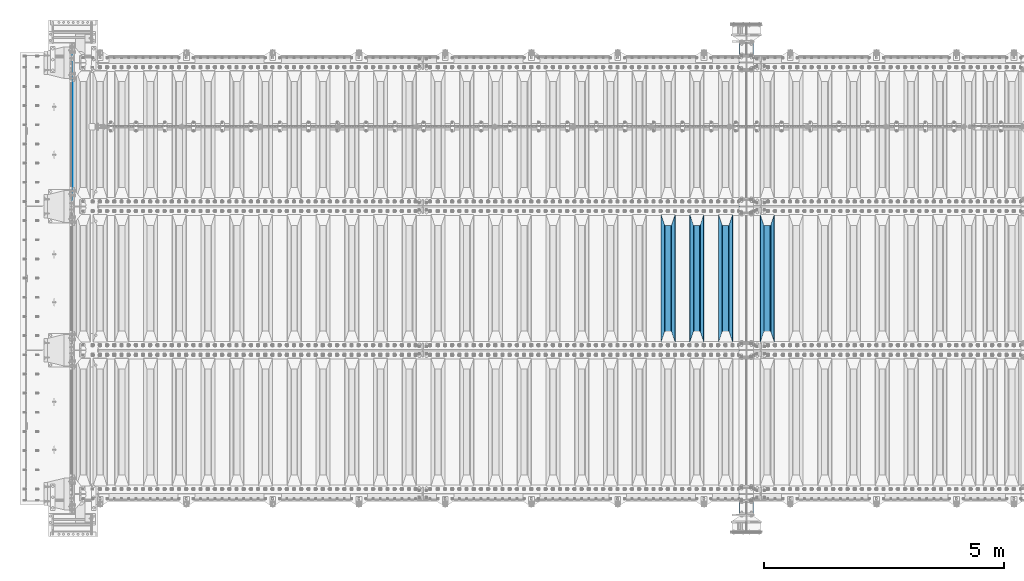
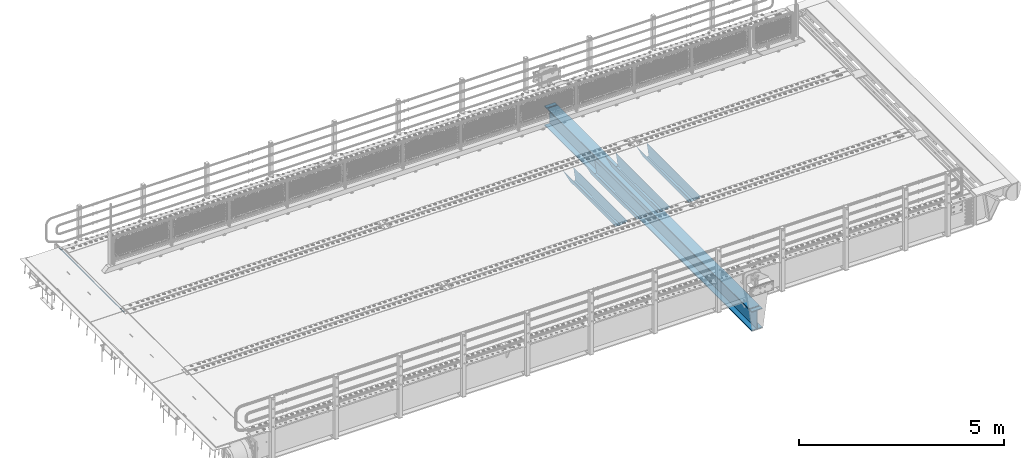
# One storey, part 126 of 270: 6 beams.
"""IFC2X3 building model written with IfcOpenShell, lengths in millimetres."""

from ifc_helpers import new_model, si_unit, frame, origin_with_axes, place, context, subcontext, project, spatial, faceted_brep, material, type_object, element, save


model = new_model("IFC2X3")

# Units and contexts
model_context = context("Model", 3, precision=1e-05, world=origin_with_axes())
body_context = subcontext(model_context, "Body", "Model", "MODEL_VIEW")
ifc_project = project(units=[si_unit("LENGTHUNIT", "METRE", prefix="MILLI"), si_unit("AREAUNIT", "SQUARE_METRE"), si_unit("VOLUMEUNIT", "CUBIC_METRE"), si_unit("MASSUNIT", "GRAM", prefix="KILO"), si_unit("TIMEUNIT", "SECOND"), si_unit("PLANEANGLEUNIT", "RADIAN"), si_unit("SOLIDANGLEUNIT", "STERADIAN"), si_unit("THERMODYNAMICTEMPERATUREUNIT", "DEGREE_CELSIUS"), si_unit("LUMINOUSINTENSITYUNIT", "LUMEN")], contexts=[model_context])

# Site, building, storey
site_placement = place(None, origin_with_axes())
site = spatial("IfcSite", under=ifc_project, at=site_placement, CompositionType="ELEMENT")
building_placement = place(site_placement, origin_with_axes())
building = spatial("IfcBuilding", under=site, at=building_placement, Name="Standard", CompositionType="ELEMENT")
storey_placement = place(building_placement, origin_with_axes())
storey = spatial("IfcBuildingStorey", under=building, at=storey_placement, Name="Undefined", CompositionType="ELEMENT", Elevation=0.0)

# Beams
ifc_material = material(Name="STEEL/S355N")
beam_type_1 = type_object("IfcBeamType", Name="D20", PredefinedType="NOTDEFINED")
beam_1_placement = place(storey_placement, frame((-35.0, -17995.0, -25.9999999971316), z_axis=(0.0, 0.0, 1.0), x_axis=(0.0, 1.0, 0.0)))
element("IfcBeam", 1, at=beam_1_placement, inside=storey, type_object=beam_type_1, material=ifc_material, ObjectType="D20", context=body_context, shape_type="Brep", body=[
    faceted_brep([(0.0, -10.0, 0.0), (0.0, -7.07106781186667, -7.07106781186547), (3144.99999999998, -7.07106781186548, -7.07106781186548), (3144.99999999998, -10.0, 0.0), (0.0, 0.0, -10.0), (3144.99999999998, 0.0, -10.0), (0.0, 7.07106781186667, -7.07106781186547), (3144.99999999998, 7.07106781186548, -7.07106781186547), (0.0, 10.0, 0.0), (3144.99999999998, 10.0, 0.0), (0.0, 7.07106781186667, 7.07106781186548), (3144.99999999998, 7.07106781186548, 7.07106781186548), (0.0, 0.0, 10.0), (3144.99999999998, 0.0, 10.0), (0.0, -7.07106781186667, 7.07106781186548), (3144.99999999998, -7.07106781186548, 7.07106781186548)], [[[0, 1, 2, 3]], [[1, 4, 5, 2]], [[4, 6, 7, 5]], [[6, 8, 9, 7]], [[8, 10, 11, 9]], [[10, 12, 13, 11]], [[12, 14, 15, 13]], [[14, 0, 3, 15]], [[5, 7, 9, 11, 13, 15, 3, 2]], [[14, 12, 10, 8, 6, 4, 1, 0]]]),
])
beam_type_2 = type_object("IfcBeamType", PredefinedType="NOTDEFINED")
beam_2_placement = place(storey_placement, frame((14470.0, -20825.0, -115.0), z_axis=(0.0, 0.0, 1.0), x_axis=(0.0, 1.0, 0.0)))
element("IfcBeam", 2, at=beam_2_placement, inside=storey, type_object=beam_type_2, material=ifc_material, context=body_context, shape_type="Brep", body=[
    faceted_brep([(0.0, 150.0, 115.0), (0.0, 143.689999999999, 115.0), (2650.00000000297, 143.689999999999, 115.0), (2650.00000000297, 150.0, 115.0), (2650.00000000297, 142.059565218398, 110.000000003096), (2650.00000000297, 148.3695652184, 110.000000003096), (2441.90079219209, -80.1103600731112, -98.0992078077845), (2437.7588105432, -77.5672621345584, -102.241189456673), (2434.06523489747, -74.4080125315522, -105.934765102404), (2430.9108609509, -70.710272125576, -109.089139048974), (2428.37322971128, -66.5649389910068, -111.626770288588), (2426.51472138055, -62.0739139532889, -113.485278619323), (2425.38102192092, -57.3475956567672, -114.618978078955), (2424.99999999987, -52.5021667386536, -115.0), (2424.99999999987, 52.5021667386536, -115.0), (2425.38102192092, 57.3475956567672, -114.618978078955), (2426.51472138055, 62.0739139532889, -113.485278619323), (2428.37322971128, 66.5649389910068, -111.626770288588), (2430.9108609509, 70.710272125576, -109.089139048974), (2434.06523489747, 74.4080125315522, -105.934765102404), (2437.7588105432, 77.5672621345584, -102.241189456673), (2441.90079219209, 80.1103600731112, -98.0992078077846), (2446.38936140511, 81.9747917625791, -93.6106385947584), (2448.2494850041, 76.2713538057251, -91.7505149957729), (2444.62967112263, 74.76777986261, -95.3703288772456), (2441.28936334126, 72.7168944282894, -98.710636658607), (2438.31067330439, 70.1691124903846, -101.689326695487), (2435.76682334747, 67.1870637758839, -104.233176652398), (2433.72034654133, 63.8440531834895, -106.279653458539), (2432.22154950042, 60.222258798236, -107.778450499454), (2431.30727574265, 56.4107117849089, -108.692724257221), (2430.99999999987, 52.5031078186876, -109.0), (2430.99999999987, -52.5031078186876, -109.0), (2431.30727574265, -56.4107117849089, -108.692724257221), (2432.22154950042, -60.222258798236, -107.778450499454), (2433.72034654133, -63.8440531834895, -106.279653458539), (2435.76682334747, -67.1870637758839, -104.233176652398), (2438.31067330438, -70.1691124903846, -101.689326695487), (2441.28936334126, -72.7168944282894, -98.7106366586071), (2444.62967112263, -74.76777986261, -95.3703288772457), (2448.2494850041, -76.2713538057251, -91.7505149957729), (2650.00000000297, -142.059565218398, 110.000000003096), (2650.00000000297, -148.3695652184, 110.000000003096), (2446.38936140511, -81.9747917625791, -93.6106385947584), (2650.00000000297, -143.689999999999, 115.0), (2650.00000000297, -150.0, 115.0), (0.0, -143.689999999999, 115.0), (0.0, -150.0, 115.0), (0.0, -148.369565218261, 110.000000002672), (203.610638597431, -81.9747917625791, -93.6106385947584), (208.099207810457, -80.1103600731112, -98.0992078077845), (212.241189459342, -77.5672621345584, -102.241189456673), (215.934765105078, -74.4080125315522, -105.934765102404), (219.089139051644, -70.710272125576, -109.089139048974), (221.626770291259, -66.5649389910068, -111.626770288588), (223.485278621993, -62.0739139532889, -113.485278619323), (224.618978081628, -57.3475956567672, -114.618978078955), (225.00000000267, -52.5021667386536, -115.0), (225.00000000267, 52.5021667386536, -115.0), (224.618978081628, 57.3475956567672, -114.618978078955), (223.485278621993, 62.0739139532889, -113.485278619323), (221.626770291259, 66.5649389910068, -111.626770288588), (219.089139051644, 70.710272125576, -109.089139048974), (215.934765105078, 74.4080125315522, -105.934765102404), (212.241189459342, 77.5672621345584, -102.241189456673), (208.099207810457, 80.1103600731112, -98.0992078077846), (203.610638597431, 81.9747917625791, -93.6106385947584), (0.0, 148.369565218261, 110.000000002672), (0.0, 142.05956521826, 110.000000002672), (201.750514998446, 76.2713538057251, -91.7505149957729), (205.370328879915, 74.76777986261, -95.3703288772456), (208.710636661279, 72.7168944282894, -98.710636658607), (211.689326698157, 70.1691124903846, -101.689326695487), (214.233176655071, 67.1870637758839, -104.233176652398), (216.27965346121, 63.8440531834895, -106.279653458539), (217.778450502126, 60.222258798236, -107.778450499454), (218.692724259894, 56.4107117849089, -108.692724257221), (219.00000000267, 52.5031078186876, -109.0), (219.00000000267, -52.5031078186876, -109.0), (218.692724259894, -56.4107117849089, -108.692724257221), (217.778450502123, -60.222258798236, -107.778450499454), (216.27965346121, -63.8440531834895, -106.279653458539), (214.233176655071, -67.1870637758839, -104.233176652398), (211.689326698157, -70.1691124903846, -101.689326695487), (208.710636661279, -72.7168944282894, -98.7106366586071), (205.370328879915, -74.76777986261, -95.3703288772457), (201.750514998446, -76.2713538057251, -91.7505149957729), (0.0, -142.05956521826, 110.000000002672)], [[[0, 1, 2, 3]], [[3, 2, 4, 5]], [[6, 7, 8, 9, 10, 11, 12, 13, 14, 15, 16, 17, 18, 19, 20, 21, 22, 5, 4, 23, 24, 25, 26, 27, 28, 29, 30, 31, 32, 33, 34, 35, 36, 37, 38, 39, 40, 41, 42, 43]], [[44, 45, 42, 41]], [[46, 47, 45, 44]], [[43, 42, 45, 47, 48, 49]], [[6, 43, 49, 50]], [[7, 6, 50, 51]], [[8, 7, 51, 52]], [[9, 8, 52, 53]], [[10, 9, 53, 54]], [[11, 10, 54, 55]], [[12, 11, 55, 56]], [[13, 12, 56, 57]], [[14, 13, 57, 58]], [[15, 14, 58, 59]], [[16, 15, 59, 60]], [[17, 16, 60, 61]], [[18, 17, 61, 62]], [[19, 18, 62, 63]], [[20, 19, 63, 64]], [[21, 20, 64, 65]], [[22, 21, 65, 66]], [[0, 3, 5, 22, 66, 67]], [[1, 0, 67, 68]], [[23, 4, 2, 1, 68, 69]], [[24, 23, 69, 70]], [[25, 24, 70, 71]], [[26, 25, 71, 72]], [[27, 26, 72, 73]], [[28, 27, 73, 74]], [[29, 28, 74, 75]], [[30, 29, 75, 76]], [[31, 30, 76, 77]], [[32, 31, 77, 78]], [[33, 32, 78, 79]], [[34, 33, 79, 80]], [[35, 34, 80, 81]], [[36, 35, 81, 82]], [[37, 36, 82, 83]], [[38, 37, 83, 84]], [[39, 38, 84, 85]], [[40, 39, 85, 86]], [[46, 44, 41, 40, 86, 87]], [[47, 46, 87, 48]], [[86, 85, 84, 83, 82, 81, 80, 79, 78, 77, 76, 75, 74, 73, 72, 71, 70, 69, 68, 67, 66, 65, 64, 63, 62, 61, 60, 59, 58, 57, 56, 55, 54, 53, 52, 51, 50, 49, 48, 87]]]),
])
beam_3_placement = place(storey_placement, frame((13600.0, -20825.0, -115.0), z_axis=(0.0, 0.0, 1.0), x_axis=(0.0, 1.0, 0.0)))
element("IfcBeam", 3, at=beam_3_placement, inside=storey, type_object=beam_type_2, material=ifc_material, context=body_context, shape_type="Brep", body=[
    faceted_brep([(0.0, 150.0, 115.0), (0.0, 143.689999999999, 115.0), (2650.00000000297, 143.689999999999, 115.0), (2650.00000000297, 150.0, 115.0), (2650.00000000297, 142.059565218398, 110.000000003096), (2650.00000000297, 148.3695652184, 110.000000003096), (2441.90079219209, -80.1103600731112, -98.0992078077845), (2437.7588105432, -77.5672621345584, -102.241189456673), (2434.06523489747, -74.4080125315522, -105.934765102404), (2430.9108609509, -70.710272125576, -109.089139048974), (2428.37322971128, -66.5649389910068, -111.626770288588), (2426.51472138055, -62.0739139532889, -113.485278619323), (2425.38102192092, -57.3475956567672, -114.618978078955), (2424.99999999987, -52.5021667386536, -115.0), (2424.99999999987, 52.5021667386536, -115.0), (2425.38102192092, 57.3475956567672, -114.618978078955), (2426.51472138055, 62.0739139532889, -113.485278619323), (2428.37322971128, 66.5649389910068, -111.626770288588), (2430.9108609509, 70.710272125576, -109.089139048974), (2434.06523489747, 74.4080125315522, -105.934765102404), (2437.7588105432, 77.5672621345584, -102.241189456673), (2441.90079219209, 80.1103600731112, -98.0992078077846), (2446.38936140511, 81.9747917625791, -93.6106385947584), (2448.2494850041, 76.2713538057251, -91.7505149957729), (2444.62967112263, 74.76777986261, -95.3703288772456), (2441.28936334126, 72.7168944282894, -98.710636658607), (2438.31067330439, 70.1691124903846, -101.689326695487), (2435.76682334747, 67.1870637758839, -104.233176652398), (2433.72034654133, 63.8440531834895, -106.279653458539), (2432.22154950042, 60.222258798236, -107.778450499454), (2431.30727574265, 56.4107117849089, -108.692724257221), (2430.99999999987, 52.5031078186876, -109.0), (2430.99999999987, -52.5031078186876, -109.0), (2431.30727574265, -56.4107117849089, -108.692724257221), (2432.22154950042, -60.222258798236, -107.778450499454), (2433.72034654133, -63.8440531834895, -106.279653458539), (2435.76682334747, -67.1870637758839, -104.233176652398), (2438.31067330438, -70.1691124903846, -101.689326695487), (2441.28936334126, -72.7168944282894, -98.7106366586071), (2444.62967112263, -74.76777986261, -95.3703288772457), (2448.2494850041, -76.2713538057251, -91.7505149957729), (2650.00000000297, -142.059565218398, 110.000000003096), (2650.00000000297, -148.3695652184, 110.000000003096), (2446.38936140511, -81.9747917625791, -93.6106385947584), (2650.00000000297, -143.689999999999, 115.0), (2650.00000000297, -150.0, 115.0), (0.0, -143.689999999999, 115.0), (0.0, -150.0, 115.0), (0.0, -148.369565218261, 110.000000002672), (203.610638597431, -81.9747917625791, -93.6106385947584), (208.099207810457, -80.1103600731112, -98.0992078077845), (212.241189459342, -77.5672621345584, -102.241189456673), (215.934765105078, -74.4080125315522, -105.934765102404), (219.089139051644, -70.710272125576, -109.089139048974), (221.626770291259, -66.5649389910068, -111.626770288588), (223.485278621993, -62.0739139532889, -113.485278619323), (224.618978081628, -57.3475956567672, -114.618978078955), (225.00000000267, -52.5021667386536, -115.0), (225.00000000267, 52.5021667386536, -115.0), (224.618978081628, 57.3475956567672, -114.618978078955), (223.485278621993, 62.0739139532889, -113.485278619323), (221.626770291259, 66.5649389910068, -111.626770288588), (219.089139051644, 70.710272125576, -109.089139048974), (215.934765105078, 74.4080125315522, -105.934765102404), (212.241189459342, 77.5672621345584, -102.241189456673), (208.099207810457, 80.1103600731112, -98.0992078077846), (203.610638597431, 81.9747917625791, -93.6106385947584), (0.0, 148.369565218261, 110.000000002672), (0.0, 142.05956521826, 110.000000002672), (201.750514998446, 76.2713538057251, -91.7505149957729), (205.370328879915, 74.76777986261, -95.3703288772456), (208.710636661279, 72.7168944282894, -98.710636658607), (211.689326698157, 70.1691124903846, -101.689326695487), (214.233176655071, 67.1870637758839, -104.233176652398), (216.27965346121, 63.8440531834895, -106.279653458539), (217.778450502126, 60.222258798236, -107.778450499454), (218.692724259894, 56.4107117849089, -108.692724257221), (219.00000000267, 52.5031078186876, -109.0), (219.00000000267, -52.5031078186876, -109.0), (218.692724259894, -56.4107117849089, -108.692724257221), (217.778450502123, -60.222258798236, -107.778450499454), (216.27965346121, -63.8440531834895, -106.279653458539), (214.233176655071, -67.1870637758839, -104.233176652398), (211.689326698157, -70.1691124903846, -101.689326695487), (208.710636661279, -72.7168944282894, -98.7106366586071), (205.370328879915, -74.76777986261, -95.3703288772457), (201.750514998446, -76.2713538057251, -91.7505149957729), (0.0, -142.05956521826, 110.000000002672)], [[[0, 1, 2, 3]], [[3, 2, 4, 5]], [[6, 7, 8, 9, 10, 11, 12, 13, 14, 15, 16, 17, 18, 19, 20, 21, 22, 5, 4, 23, 24, 25, 26, 27, 28, 29, 30, 31, 32, 33, 34, 35, 36, 37, 38, 39, 40, 41, 42, 43]], [[44, 45, 42, 41]], [[46, 47, 45, 44]], [[43, 42, 45, 47, 48, 49]], [[6, 43, 49, 50]], [[7, 6, 50, 51]], [[8, 7, 51, 52]], [[9, 8, 52, 53]], [[10, 9, 53, 54]], [[11, 10, 54, 55]], [[12, 11, 55, 56]], [[13, 12, 56, 57]], [[14, 13, 57, 58]], [[15, 14, 58, 59]], [[16, 15, 59, 60]], [[17, 16, 60, 61]], [[18, 17, 61, 62]], [[19, 18, 62, 63]], [[20, 19, 63, 64]], [[21, 20, 64, 65]], [[22, 21, 65, 66]], [[0, 3, 5, 22, 66, 67]], [[1, 0, 67, 68]], [[23, 4, 2, 1, 68, 69]], [[24, 23, 69, 70]], [[25, 24, 70, 71]], [[26, 25, 71, 72]], [[27, 26, 72, 73]], [[28, 27, 73, 74]], [[29, 28, 74, 75]], [[30, 29, 75, 76]], [[31, 30, 76, 77]], [[32, 31, 77, 78]], [[33, 32, 78, 79]], [[34, 33, 79, 80]], [[35, 34, 80, 81]], [[36, 35, 81, 82]], [[37, 36, 82, 83]], [[38, 37, 83, 84]], [[39, 38, 84, 85]], [[40, 39, 85, 86]], [[46, 44, 41, 40, 86, 87]], [[47, 46, 87, 48]], [[86, 85, 84, 83, 82, 81, 80, 79, 78, 77, 76, 75, 74, 73, 72, 71, 70, 69, 68, 67, 66, 65, 64, 63, 62, 61, 60, 59, 58, 57, 56, 55, 54, 53, 52, 51, 50, 49, 48, 87]]]),
])
beam_4_placement = place(storey_placement, frame((13000.0, -20825.0, -115.0), z_axis=(0.0, 0.0, 1.0), x_axis=(0.0, 1.0, 0.0)))
element("IfcBeam", 4, at=beam_4_placement, inside=storey, type_object=beam_type_2, material=ifc_material, context=body_context, shape_type="Brep", body=[
    faceted_brep([(0.0, 150.0, 115.0), (0.0, 143.689999999999, 115.0), (2650.00000000297, 143.689999999999, 115.0), (2650.00000000297, 150.0, 115.0), (2650.00000000297, 142.059565218398, 110.000000003096), (2650.00000000297, 148.3695652184, 110.000000003096), (2441.90079219209, -80.1103600731112, -98.0992078077845), (2437.7588105432, -77.5672621345584, -102.241189456673), (2434.06523489747, -74.4080125315522, -105.934765102404), (2430.9108609509, -70.710272125576, -109.089139048974), (2428.37322971128, -66.5649389910068, -111.626770288588), (2426.51472138055, -62.0739139532889, -113.485278619323), (2425.38102192092, -57.3475956567672, -114.618978078955), (2424.99999999987, -52.5021667386536, -115.0), (2424.99999999987, 52.5021667386536, -115.0), (2425.38102192092, 57.3475956567672, -114.618978078955), (2426.51472138055, 62.0739139532889, -113.485278619323), (2428.37322971128, 66.5649389910068, -111.626770288588), (2430.9108609509, 70.710272125576, -109.089139048974), (2434.06523489747, 74.4080125315522, -105.934765102404), (2437.7588105432, 77.5672621345584, -102.241189456673), (2441.90079219209, 80.1103600731112, -98.0992078077846), (2446.38936140511, 81.9747917625791, -93.6106385947584), (2448.2494850041, 76.2713538057251, -91.7505149957729), (2444.62967112263, 74.76777986261, -95.3703288772456), (2441.28936334126, 72.7168944282894, -98.710636658607), (2438.31067330439, 70.1691124903846, -101.689326695487), (2435.76682334747, 67.1870637758839, -104.233176652398), (2433.72034654133, 63.8440531834895, -106.279653458539), (2432.22154950042, 60.222258798236, -107.778450499454), (2431.30727574265, 56.4107117849089, -108.692724257221), (2430.99999999987, 52.5031078186876, -109.0), (2430.99999999987, -52.5031078186876, -109.0), (2431.30727574265, -56.4107117849089, -108.692724257221), (2432.22154950042, -60.222258798236, -107.778450499454), (2433.72034654133, -63.8440531834895, -106.279653458539), (2435.76682334747, -67.1870637758839, -104.233176652398), (2438.31067330438, -70.1691124903846, -101.689326695487), (2441.28936334126, -72.7168944282894, -98.7106366586071), (2444.62967112263, -74.76777986261, -95.3703288772457), (2448.2494850041, -76.2713538057251, -91.7505149957729), (2650.00000000297, -142.059565218398, 110.000000003096), (2650.00000000297, -148.3695652184, 110.000000003096), (2446.38936140511, -81.9747917625791, -93.6106385947584), (2650.00000000297, -143.689999999999, 115.0), (2650.00000000297, -150.0, 115.0), (0.0, -143.689999999999, 115.0), (0.0, -150.0, 115.0), (0.0, -148.369565218261, 110.000000002672), (203.610638597431, -81.9747917625791, -93.6106385947584), (208.099207810457, -80.1103600731112, -98.0992078077845), (212.241189459342, -77.5672621345584, -102.241189456673), (215.934765105078, -74.4080125315522, -105.934765102404), (219.089139051644, -70.710272125576, -109.089139048974), (221.626770291259, -66.5649389910068, -111.626770288588), (223.485278621993, -62.0739139532889, -113.485278619323), (224.618978081628, -57.3475956567672, -114.618978078955), (225.00000000267, -52.5021667386536, -115.0), (225.00000000267, 52.5021667386536, -115.0), (224.618978081628, 57.3475956567672, -114.618978078955), (223.485278621993, 62.0739139532889, -113.485278619323), (221.626770291259, 66.5649389910068, -111.626770288588), (219.089139051644, 70.710272125576, -109.089139048974), (215.934765105078, 74.4080125315522, -105.934765102404), (212.241189459342, 77.5672621345584, -102.241189456673), (208.099207810457, 80.1103600731112, -98.0992078077846), (203.610638597431, 81.9747917625791, -93.6106385947584), (0.0, 148.369565218261, 110.000000002672), (0.0, 142.05956521826, 110.000000002672), (201.750514998446, 76.2713538057251, -91.7505149957729), (205.370328879915, 74.76777986261, -95.3703288772456), (208.710636661279, 72.7168944282894, -98.710636658607), (211.689326698157, 70.1691124903846, -101.689326695487), (214.233176655071, 67.1870637758839, -104.233176652398), (216.27965346121, 63.8440531834895, -106.279653458539), (217.778450502126, 60.222258798236, -107.778450499454), (218.692724259894, 56.4107117849089, -108.692724257221), (219.00000000267, 52.5031078186876, -109.0), (219.00000000267, -52.5031078186876, -109.0), (218.692724259894, -56.4107117849089, -108.692724257221), (217.778450502123, -60.222258798236, -107.778450499454), (216.27965346121, -63.8440531834895, -106.279653458539), (214.233176655071, -67.1870637758839, -104.233176652398), (211.689326698157, -70.1691124903846, -101.689326695487), (208.710636661279, -72.7168944282894, -98.7106366586071), (205.370328879915, -74.76777986261, -95.3703288772457), (201.750514998446, -76.2713538057251, -91.7505149957729), (0.0, -142.05956521826, 110.000000002672)], [[[0, 1, 2, 3]], [[3, 2, 4, 5]], [[6, 7, 8, 9, 10, 11, 12, 13, 14, 15, 16, 17, 18, 19, 20, 21, 22, 5, 4, 23, 24, 25, 26, 27, 28, 29, 30, 31, 32, 33, 34, 35, 36, 37, 38, 39, 40, 41, 42, 43]], [[44, 45, 42, 41]], [[46, 47, 45, 44]], [[43, 42, 45, 47, 48, 49]], [[6, 43, 49, 50]], [[7, 6, 50, 51]], [[8, 7, 51, 52]], [[9, 8, 52, 53]], [[10, 9, 53, 54]], [[11, 10, 54, 55]], [[12, 11, 55, 56]], [[13, 12, 56, 57]], [[14, 13, 57, 58]], [[15, 14, 58, 59]], [[16, 15, 59, 60]], [[17, 16, 60, 61]], [[18, 17, 61, 62]], [[19, 18, 62, 63]], [[20, 19, 63, 64]], [[21, 20, 64, 65]], [[22, 21, 65, 66]], [[0, 3, 5, 22, 66, 67]], [[1, 0, 67, 68]], [[23, 4, 2, 1, 68, 69]], [[24, 23, 69, 70]], [[25, 24, 70, 71]], [[26, 25, 71, 72]], [[27, 26, 72, 73]], [[28, 27, 73, 74]], [[29, 28, 74, 75]], [[30, 29, 75, 76]], [[31, 30, 76, 77]], [[32, 31, 77, 78]], [[33, 32, 78, 79]], [[34, 33, 79, 80]], [[35, 34, 80, 81]], [[36, 35, 81, 82]], [[37, 36, 82, 83]], [[38, 37, 83, 84]], [[39, 38, 84, 85]], [[40, 39, 85, 86]], [[46, 44, 41, 40, 86, 87]], [[47, 46, 87, 48]], [[86, 85, 84, 83, 82, 81, 80, 79, 78, 77, 76, 75, 74, 73, 72, 71, 70, 69, 68, 67, 66, 65, 64, 63, 62, 61, 60, 59, 58, 57, 56, 55, 54, 53, 52, 51, 50, 49, 48, 87]]]),
])
beam_5_placement = place(storey_placement, frame((12400.0, -20825.0, -115.0), z_axis=(0.0, 0.0, 1.0), x_axis=(0.0, 1.0, 0.0)))
element("IfcBeam", 5, at=beam_5_placement, inside=storey, type_object=beam_type_2, material=ifc_material, context=body_context, shape_type="Brep", body=[
    faceted_brep([(0.0, 150.0, 115.0), (0.0, 143.689999999999, 115.0), (2650.00000000297, 143.689999999999, 115.0), (2650.00000000297, 150.0, 115.0), (2650.00000000297, 142.059565218398, 110.000000003096), (2650.00000000297, 148.3695652184, 110.000000003096), (2441.90079219209, -80.1103600731112, -98.0992078077845), (2437.7588105432, -77.5672621345584, -102.241189456673), (2434.06523489747, -74.4080125315522, -105.934765102404), (2430.9108609509, -70.710272125576, -109.089139048974), (2428.37322971128, -66.5649389910068, -111.626770288588), (2426.51472138055, -62.0739139532889, -113.485278619323), (2425.38102192092, -57.3475956567672, -114.618978078955), (2424.99999999987, -52.5021667386536, -115.0), (2424.99999999987, 52.5021667386536, -115.0), (2425.38102192092, 57.3475956567672, -114.618978078955), (2426.51472138055, 62.0739139532889, -113.485278619323), (2428.37322971128, 66.5649389910068, -111.626770288588), (2430.9108609509, 70.710272125576, -109.089139048974), (2434.06523489747, 74.4080125315522, -105.934765102404), (2437.7588105432, 77.5672621345584, -102.241189456673), (2441.90079219209, 80.1103600731112, -98.0992078077846), (2446.38936140511, 81.9747917625791, -93.6106385947584), (2448.2494850041, 76.2713538057251, -91.7505149957729), (2444.62967112263, 74.76777986261, -95.3703288772456), (2441.28936334126, 72.7168944282894, -98.710636658607), (2438.31067330439, 70.1691124903846, -101.689326695487), (2435.76682334747, 67.1870637758839, -104.233176652398), (2433.72034654133, 63.8440531834895, -106.279653458539), (2432.22154950042, 60.222258798236, -107.778450499454), (2431.30727574265, 56.4107117849089, -108.692724257221), (2430.99999999987, 52.5031078186876, -109.0), (2430.99999999987, -52.5031078186876, -109.0), (2431.30727574265, -56.4107117849089, -108.692724257221), (2432.22154950042, -60.222258798236, -107.778450499454), (2433.72034654133, -63.8440531834895, -106.279653458539), (2435.76682334747, -67.1870637758839, -104.233176652398), (2438.31067330438, -70.1691124903846, -101.689326695487), (2441.28936334126, -72.7168944282894, -98.7106366586071), (2444.62967112263, -74.76777986261, -95.3703288772457), (2448.2494850041, -76.2713538057251, -91.7505149957729), (2650.00000000297, -142.059565218398, 110.000000003096), (2650.00000000297, -148.3695652184, 110.000000003096), (2446.38936140511, -81.9747917625791, -93.6106385947584), (2650.00000000297, -143.689999999999, 115.0), (2650.00000000297, -150.0, 115.0), (0.0, -143.689999999999, 115.0), (0.0, -150.0, 115.0), (0.0, -148.369565218261, 110.000000002672), (203.610638597431, -81.9747917625791, -93.6106385947584), (208.099207810457, -80.1103600731112, -98.0992078077845), (212.241189459342, -77.5672621345584, -102.241189456673), (215.934765105078, -74.4080125315522, -105.934765102404), (219.089139051644, -70.710272125576, -109.089139048974), (221.626770291259, -66.5649389910068, -111.626770288588), (223.485278621993, -62.0739139532889, -113.485278619323), (224.618978081628, -57.3475956567672, -114.618978078955), (225.00000000267, -52.5021667386536, -115.0), (225.00000000267, 52.5021667386536, -115.0), (224.618978081628, 57.3475956567672, -114.618978078955), (223.485278621993, 62.0739139532889, -113.485278619323), (221.626770291259, 66.5649389910068, -111.626770288588), (219.089139051644, 70.710272125576, -109.089139048974), (215.934765105078, 74.4080125315522, -105.934765102404), (212.241189459342, 77.5672621345584, -102.241189456673), (208.099207810457, 80.1103600731112, -98.0992078077846), (203.610638597431, 81.9747917625791, -93.6106385947584), (0.0, 148.369565218261, 110.000000002672), (0.0, 142.05956521826, 110.000000002672), (201.750514998446, 76.2713538057251, -91.7505149957729), (205.370328879915, 74.76777986261, -95.3703288772456), (208.710636661279, 72.7168944282894, -98.710636658607), (211.689326698157, 70.1691124903846, -101.689326695487), (214.233176655071, 67.1870637758839, -104.233176652398), (216.27965346121, 63.8440531834895, -106.279653458539), (217.778450502126, 60.222258798236, -107.778450499454), (218.692724259894, 56.4107117849089, -108.692724257221), (219.00000000267, 52.5031078186876, -109.0), (219.00000000267, -52.5031078186876, -109.0), (218.692724259894, -56.4107117849089, -108.692724257221), (217.778450502123, -60.222258798236, -107.778450499454), (216.27965346121, -63.8440531834895, -106.279653458539), (214.233176655071, -67.1870637758839, -104.233176652398), (211.689326698157, -70.1691124903846, -101.689326695487), (208.710636661279, -72.7168944282894, -98.7106366586071), (205.370328879915, -74.76777986261, -95.3703288772457), (201.750514998446, -76.2713538057251, -91.7505149957729), (0.0, -142.05956521826, 110.000000002672)], [[[0, 1, 2, 3]], [[3, 2, 4, 5]], [[6, 7, 8, 9, 10, 11, 12, 13, 14, 15, 16, 17, 18, 19, 20, 21, 22, 5, 4, 23, 24, 25, 26, 27, 28, 29, 30, 31, 32, 33, 34, 35, 36, 37, 38, 39, 40, 41, 42, 43]], [[44, 45, 42, 41]], [[46, 47, 45, 44]], [[43, 42, 45, 47, 48, 49]], [[6, 43, 49, 50]], [[7, 6, 50, 51]], [[8, 7, 51, 52]], [[9, 8, 52, 53]], [[10, 9, 53, 54]], [[11, 10, 54, 55]], [[12, 11, 55, 56]], [[13, 12, 56, 57]], [[14, 13, 57, 58]], [[15, 14, 58, 59]], [[16, 15, 59, 60]], [[17, 16, 60, 61]], [[18, 17, 61, 62]], [[19, 18, 62, 63]], [[20, 19, 63, 64]], [[21, 20, 64, 65]], [[22, 21, 65, 66]], [[0, 3, 5, 22, 66, 67]], [[1, 0, 67, 68]], [[23, 4, 2, 1, 68, 69]], [[24, 23, 69, 70]], [[25, 24, 70, 71]], [[26, 25, 71, 72]], [[27, 26, 72, 73]], [[28, 27, 73, 74]], [[29, 28, 74, 75]], [[30, 29, 75, 76]], [[31, 30, 76, 77]], [[32, 31, 77, 78]], [[33, 32, 78, 79]], [[34, 33, 79, 80]], [[35, 34, 80, 81]], [[36, 35, 81, 82]], [[37, 36, 82, 83]], [[38, 37, 83, 84]], [[39, 38, 84, 85]], [[40, 39, 85, 86]], [[46, 44, 41, 40, 86, 87]], [[47, 46, 87, 48]], [[86, 85, 84, 83, 82, 81, 80, 79, 78, 77, 76, 75, 74, 73, 72, 71, 70, 69, 68, 67, 66, 65, 64, 63, 62, 61, 60, 59, 58, 57, 56, 55, 54, 53, 52, 51, 50, 49, 48, 87]]]),
])
beam_type_3 = type_object("IfcBeamType", Name="HEA600", PredefinedType="NOTDEFINED")
beam_6_placement = place(storey_placement, frame((14034.9999999799, -24564.9999999541, -1195.00001820563), z_axis=(0.0, 0.0, 1.0), x_axis=(0.0, 1.0, 0.0)))
element("IfcBeam", 6, at=beam_6_placement, inside=storey, type_object=beam_type_3, material=ifc_material, ObjectType="HEA600", context=body_context, shape_type="Brep", body=[
    faceted_brep([(9989.99999999952, -150.000000000371, 295.0), (9989.99999999952, -150.0, 270.0), (9989.99999999952, -6.5, 270.0), (9989.99999999952, -6.5, 295.0), (10019.9999999995, -6.5, 270.0), (10019.9999999995, -6.5, 295.0), (10019.9999999995, -150.0, 295.0), (10019.9999999995, -150.0, 270.0), (10129.9999999995, -150.0, 270.0), (10129.9999999995, -150.0, 295.0), (10129.9999999995, -6.5, 270.0), (10129.9999999995, 150.0, 295.0), (10129.9999999995, 150.0, 270.0), (10019.9999999995, 150.0, 270.0), (10019.9999999995, 150.0, 295.0), (140.000000022676, 6.5, 270.0), (140.000000303196, 150.0, 270.0), (9989.99999999952, 150.0, 270.0), (9989.99999999952, 6.5, 270.0), (0.0, -150.0, -295.0), (0.0, 150.0, -295.0), (10129.9999999995, 150.0, -295.0), (10129.9999999995, -150.0, -295.0), (10019.9999999995, -150.0, -270.0), (9989.99999999952, -150.0, -270.0), (139.999999716645, -150.0, -270.0), (109.999999716645, -150.0, -270.0), (0.0, -150.0, -270.0), (10129.9999999995, -150.0, -270.0), (10019.9999999995, -6.5, -270.0), (9989.99999999952, -6.5, -270.0), (140.000000003482, -6.5, -270.0), (110.000000003645, -6.5, -270.0), (0.0, -6.5, -270.0), (10129.9999999995, -6.5, -270.0), (0.0, -150.0, 270.0), (0.0, -6.5, 270.0), (110.000000003645, -6.5, 270.0), (109.999999716649, -150.0, 270.0), (139.999999716645, -150.000000026435, 295.0), (140.000000003482, -6.50000002643537, 295.0), (140.000000003482, -6.5, 270.0), (139.999999716645, -150.0, 270.0), (110.000000003645, -6.49999996643601, 295.0), (109.999999716649, -150.0, 295.0), (0.0, -150.0, 295.0), (0.0, 6.5, 270.0), (0.0, 150.0, 270.0), (110.000000303196, 150.0, 270.0), (110.000000303196, 6.5, 270.0), (0.0, 150.0, 295.0), (0.0, 6.5, -270.0), (0.0, 150.0, -270.0), (110.000000303196, 150.0, 295.0), (110.000000303196, 6.49999997436862, 295.0), (140.000000022676, 6.49999997436862, 295.0), (140.000000303196, 150.0, 295.0), (9989.99999999952, 150.0, 295.0), (9989.99999999952, 6.5, 295.0), (10019.9999999995, 6.5, 295.0), (10019.9999999995, 6.5, 270.0), (10129.9999999995, 6.5, 270.0), (10019.9999999995, 6.5, -270.0), (9989.99999999952, 6.5, -270.0), (140.000000022676, 6.5, -270.0), (110.000000303196, 6.5, -270.0), (10129.9999999995, 6.5, -270.0), (10019.9999999995, 150.0, -270.0), (9989.99999999952, 150.0, -270.0), (140.000000303196, 150.0, -270.0), (110.000000303196, 150.0, -270.0), (10129.9999999995, 150.0, -270.0)], [[[0, 1, 2, 3]], [[3, 2, 4, 5]], [[6, 5, 4, 7]], [[8, 9, 6, 7]], [[10, 8, 7, 4]], [[11, 12, 13, 14]], [[15, 16, 17, 18]], [[19, 20, 21, 22]], [[23, 24, 25, 26, 27, 19, 22, 28]], [[29, 30, 31, 32, 33, 27, 26, 25, 24, 23, 28, 34]], [[35, 36, 37, 38]], [[39, 40, 41, 42]], [[43, 37, 41, 40]], [[44, 38, 37, 43]], [[45, 35, 38, 44]], [[46, 47, 48, 49]], [[19, 27, 33, 36, 35, 45, 50, 47, 46, 51, 52, 20]], [[47, 50, 53, 48]], [[54, 49, 48, 53]], [[55, 15, 49, 54]], [[56, 16, 15, 55]], [[16, 56, 57, 17]], [[58, 18, 17, 57]], [[59, 60, 18, 58]], [[14, 13, 60, 59]], [[12, 61, 60, 13]], [[62, 63, 64, 65, 51, 46, 49, 15, 18, 60, 61, 66]], [[67, 68, 69, 70, 52, 51, 65, 64, 63, 62, 66, 71]], [[20, 52, 70, 69, 68, 67, 71, 21]], [[66, 61, 12, 11, 9, 8, 10, 34, 28, 22, 21, 71]], [[4, 2, 41, 37, 36, 33, 32, 31, 30, 29, 34, 10]], [[42, 41, 2, 1]], [[39, 42, 1, 0]], [[9, 11, 14, 59, 58, 57, 56, 55, 54, 53, 50, 45, 44, 43, 40, 39, 0, 3, 5, 6]]]),
])

save(model, "model.ifc")
